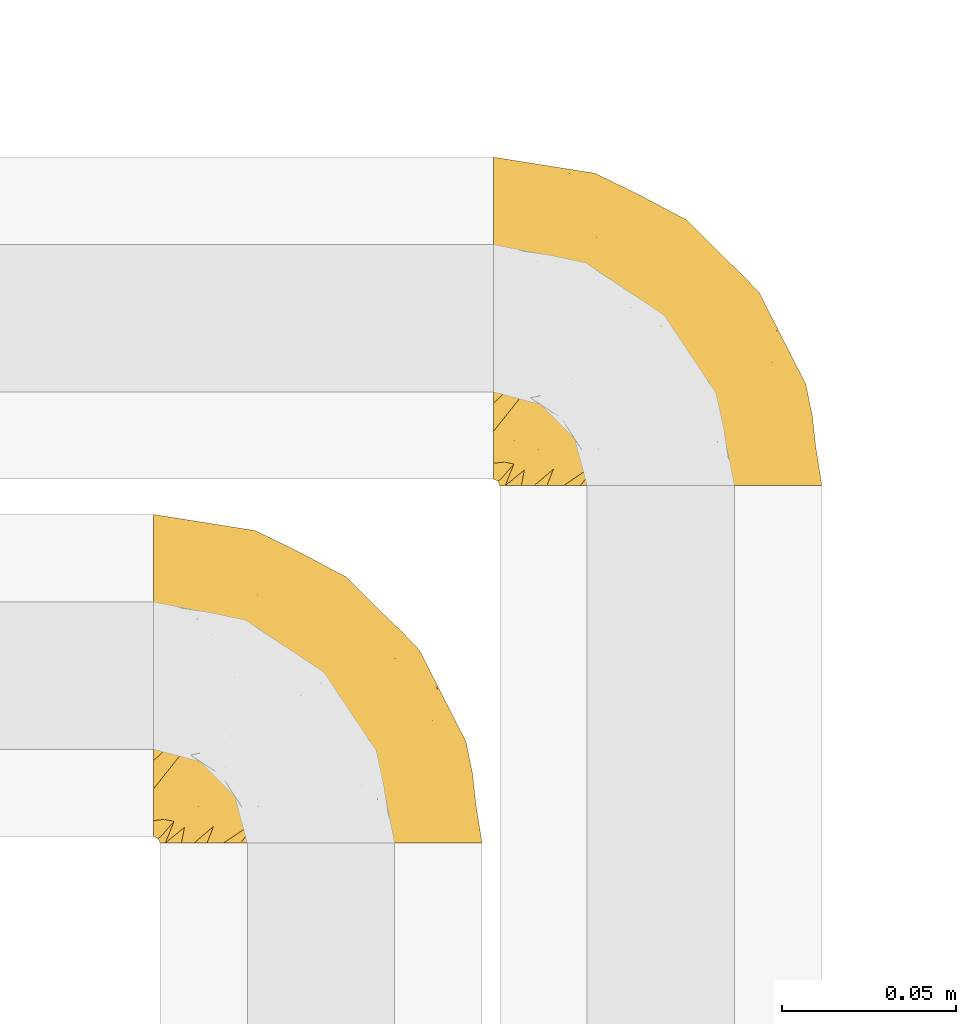
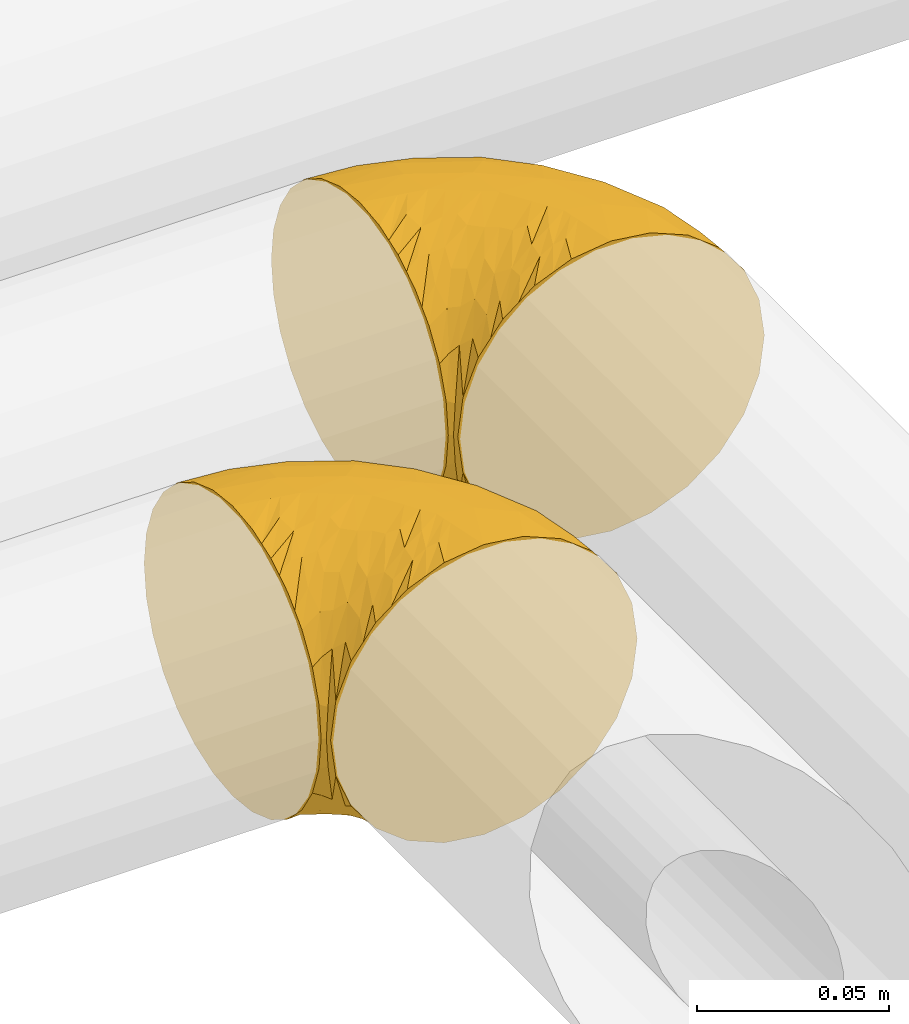
# One storey, part 322 of 827: 2 coverings.
"""IFC2X3 building model written with IfcOpenShell, lengths in millimetres."""

from ifc_helpers import new_model, entity, si_unit, converted_unit, derived_unit, direction, frame, origin, place, context, subcontext, project, spatial, faceted_brep, element, save


model = new_model("IFC2X3")

# Units and contexts
model_context = context("Model", 3, precision=0.01, world=origin(), true_north=direction((6.12303176911189e-17, 1.0)))
body_context = subcontext(model_context, "Body", "Model", "MODEL_VIEW")
ifc_project = project(units=[si_unit("LENGTHUNIT", "METRE", prefix="MILLI"), si_unit("AREAUNIT", "SQUARE_METRE"), si_unit("VOLUMEUNIT", "CUBIC_METRE"), converted_unit("PLANEANGLEUNIT", "DEGREE", entity("IfcRatioMeasure", 0.0174532925199433), si_unit("PLANEANGLEUNIT", "RADIAN"), dimensions=[0, 0, 0, 0, 0, 0, 0]), si_unit("MASSUNIT", "GRAM", prefix="KILO"), derived_unit("MASSDENSITYUNIT", [(si_unit("MASSUNIT", "GRAM", prefix="KILO"), 1), (si_unit("LENGTHUNIT", "METRE"), -3)]), derived_unit("MOMENTOFINERTIAUNIT", [(si_unit("LENGTHUNIT", "METRE"), 4)]), si_unit("TIMEUNIT", "SECOND"), si_unit("FREQUENCYUNIT", "HERTZ"), si_unit("THERMODYNAMICTEMPERATUREUNIT", "DEGREE_CELSIUS"), derived_unit("THERMALTRANSMITTANCEUNIT", [(si_unit("MASSUNIT", "GRAM", prefix="KILO"), 1), (si_unit("THERMODYNAMICTEMPERATUREUNIT", "KELVIN"), -1), (si_unit("TIMEUNIT", "SECOND"), -3)]), derived_unit("VOLUMETRICFLOWRATEUNIT", [(si_unit("LENGTHUNIT", "METRE"), 3), (si_unit("TIMEUNIT", "SECOND"), -1)]), derived_unit("MASSFLOWRATEUNIT", [(si_unit("MASSUNIT", "GRAM", prefix="KILO"), 1), (si_unit("TIMEUNIT", "SECOND"), -1)]), derived_unit("ROTATIONALFREQUENCYUNIT", [(si_unit("TIMEUNIT", "SECOND"), -1)]), si_unit("ELECTRICCURRENTUNIT", "AMPERE"), si_unit("ELECTRICVOLTAGEUNIT", "VOLT"), si_unit("POWERUNIT", "WATT"), si_unit("FORCEUNIT", "NEWTON", prefix="KILO"), si_unit("ILLUMINANCEUNIT", "LUX"), si_unit("LUMINOUSFLUXUNIT", "LUMEN"), si_unit("LUMINOUSINTENSITYUNIT", "CANDELA"), derived_unit("USERDEFINED", [(si_unit("MASSUNIT", "GRAM", prefix="KILO"), -1), (si_unit("LENGTHUNIT", "METRE"), -2), (si_unit("TIMEUNIT", "SECOND"), 3), (si_unit("LUMINOUSFLUXUNIT", "LUMEN"), 1)]), derived_unit("LINEARVELOCITYUNIT", [(si_unit("LENGTHUNIT", "METRE"), 1), (si_unit("TIMEUNIT", "SECOND"), -1)]), si_unit("PRESSUREUNIT", "PASCAL"), derived_unit("USERDEFINED", [(si_unit("LENGTHUNIT", "METRE"), -2), (si_unit("MASSUNIT", "GRAM", prefix="KILO"), 1), (si_unit("TIMEUNIT", "SECOND"), -2)]), derived_unit("LINEARFORCEUNIT", [(si_unit("MASSUNIT", "GRAM", prefix="KILO"), 1), (si_unit("LENGTHUNIT", "METRE"), 1), (si_unit("TIMEUNIT", "SECOND"), -2), (si_unit("LENGTHUNIT", "METRE"), -1)]), derived_unit("PLANARFORCEUNIT", [(si_unit("MASSUNIT", "GRAM", prefix="KILO"), 1), (si_unit("LENGTHUNIT", "METRE"), 1), (si_unit("TIMEUNIT", "SECOND"), -2), (si_unit("LENGTHUNIT", "METRE"), -2)])], contexts=[model_context])

# Site, building, storey
site_placement = place(None, origin())
site = spatial("IfcSite", under=ifc_project, at=site_placement, CompositionType="ELEMENT")
building_placement = place(site_placement, origin())
building = spatial("IfcBuilding", under=site, at=building_placement, CompositionType="ELEMENT")
storey_placement = place(building_placement, frame((0.0, 0.0, 28200.0)))
storey = spatial("IfcBuildingStorey", under=building, at=storey_placement, Name="08", CompositionType="ELEMENT", Elevation=28200.0)

# Coverings
covering_1_placement = place(storey_placement, frame((32320.44, 18547.91, 2951.71)))
element("IfcCovering", 1, at=covering_1_placement, inside=storey, Name=":ADSK_", ObjectType=":ADSK_", PredefinedType="INSULATION", context=body_context, shape_type="Brep", body=[
    faceted_brep([(1.6, 59.88, 92.84), (1.6, 69.65, 89.42), (1.6, 78.41, 83.91), (1.6, 85.72, 76.59), (1.6, 91.22, 67.83), (1.6, 94.64, 58.07), (1.6, 95.8, 47.8), (1.6, 94.64, 37.51), (1.6, 91.22, 27.74), (1.6, 85.71, 18.98), (1.6, 78.39, 11.67), (1.6, 69.63, 6.17), (1.6, 59.87, 2.75), (1.6, 49.6, 1.6), (1.6, 45.45, 2.06), (1.6, 42.38, 2.41), (1.6, 39.31, 2.75), (1.6, 34.43, 4.46), (1.6, 29.54, 6.17), (1.6, 25.16, 8.93), (1.6, 20.78, 11.68), (1.6, 17.13, 15.34), (1.6, 13.47, 19.0), (1.6, 7.97, 27.76), (1.6, 6.26, 32.64), (1.6, 4.55, 37.52), (1.6, 3.4, 47.8), (1.6, 4.55, 58.08), (1.6, 6.26, 62.96), (1.6, 7.97, 67.85), (1.6, 13.48, 76.61), (1.6, 17.14, 80.26), (1.6, 20.8, 83.92), (1.6, 25.18, 86.67), (1.6, 29.56, 89.42), (1.6, 34.44, 91.13), (1.6, 39.32, 92.84), (1.6, 42.39, 93.18), (1.6, 45.45, 93.53), (1.6, 49.6, 94.0), (3.4, 1.6, 47.8), (4.97, 1.6, 35.84), (9.58, 1.6, 24.7), (13.26, 1.6, 19.91), (16.93, 1.6, 15.13), (21.71, 1.6, 11.46), (26.5, 1.6, 7.78), (32.07, 1.6, 5.48), (37.64, 1.6, 3.17), (41.25, 1.6, 2.69), (43.34, 1.6, 2.42), (45.42, 1.6, 2.14), (49.6, 1.6, 1.6), (61.55, 1.6, 3.17), (72.7, 1.6, 7.78), (82.26, 1.6, 15.13), (89.61, 1.6, 24.7), (94.22, 1.6, 35.84), (95.8, 1.6, 47.8), (94.22, 1.6, 59.75), (89.61, 1.6, 70.9), (82.26, 1.6, 80.46), (72.7, 1.6, 87.81), (61.55, 1.6, 92.42), (49.6, 1.6, 94.0), (45.42, 1.6, 93.45), (41.25, 1.6, 92.9), (37.64, 1.6, 92.42), (32.07, 1.6, 90.11), (26.5, 1.6, 87.81), (21.71, 1.6, 84.13), (16.93, 1.6, 80.46), (13.26, 1.6, 75.68), (9.58, 1.6, 70.9), (4.97, 1.6, 59.75), (81.55, 36.81, 71.98), (90.4, 23.28, 63.6), (83.0, 45.8, 59.72), (91.18, 30.7, 47.8), (93.13, 21.2, 55.16), (94.0, 12.96, 47.8), (66.19, 66.19, 63.76), (70.92, 54.51, 72.22), (85.95, 17.98, 74.18), (49.74, 36.69, 92.52), (35.54, 35.54, 94.0), (38.14, 31.64, 94.0), (40.74, 27.75, 94.0), (43.34, 23.86, 94.0), (45.94, 19.96, 94.0), (77.59, 22.8, 82.14), (71.17, 42.67, 80.34), (65.81, 33.21, 87.52), (59.03, 59.45, 79.59), (45.85, 71.5, 78.25), (45.79, 62.66, 85.01), (41.42, 54.5, 90.25), (34.51, 47.57, 93.2), (56.04, 48.81, 87.23), (15.15, 74.98, 85.55), (56.51, 18.7, 93.0), (68.39, 15.75, 89.31), (23.33, 91.17, 61.31), (42.86, 85.28, 56.86), (39.42, 82.58, 68.34), (53.58, 75.78, 65.71), (59.17, 74.98, 56.99), (59.06, 67.27, 72.15), (22.63, 87.38, 70.34), (20.55, 82.04, 78.36), (12.96, 94.0, 47.8), (56.96, 77.8, 47.8), (67.38, 67.38, 47.8), (18.72, 56.2, 93.06), (5.33, 48.85, 94.0), (9.07, 48.11, 94.0), (11.79, 47.57, 94.0), (14.51, 47.03, 94.0), (17.24, 46.48, 94.0), (19.96, 45.94, 94.0), (21.03, 65.78, 89.88), (46.48, 17.24, 94.0), (47.03, 14.51, 94.0), (47.57, 11.79, 94.0), (48.11, 9.07, 94.0), (48.48, 7.2, 94.0), (48.85, 5.33, 94.0), (30.7, 91.18, 47.8), (23.86, 43.34, 94.0), (27.75, 40.74, 94.0), (31.64, 38.14, 94.0), (31.26, 72.73, 83.7), (77.8, 56.96, 47.8), (72.75, 62.23, 55.9), (43.83, 84.49, 47.8), (84.49, 43.83, 47.8), (14.58, 12.05, 81.75), (16.17, 18.95, 86.43), (10.82, 13.02, 79.8), (4.64, 8.34, 69.84), (7.71, 14.63, 79.5), (25.13, 11.09, 88.08), (32.66, 13.66, 91.6), (34.94, 20.08, 92.93), (36.76, 9.61, 92.43), (40.48, 9.48, 93.24), (39.25, 16.1, 93.36), (3.69, 3.42, 57.25), (13.99, 26.63, 89.41), (21.85, 33.72, 92.89), (17.93, 34.77, 92.66), (15.11, 6.75, 79.58), (21.14, 13.31, 86.51), (12.7, 21.11, 86.29), (7.21, 19.94, 83.91), (10.45, 6.04, 73.94), (32.27, 8.67, 90.94), (25.68, 26.11, 91.94), (22.18, 29.3, 91.98), (18.79, 6.32, 82.79), (10.12, 39.92, 93.16), (9.47, 27.05, 88.76), (11.29, 34.4, 91.89), (2.87, 2.87, 47.8), (31.16, 20.92, 92.22), (6.31, 27.43, 88.56), (25.62, 7.54, 87.72), (21.18, 18.45, 88.33), (28.81, 23.88, 92.18), (7.45, 7.77, 71.78), (21.14, 13.3, 9.09), (25.13, 11.09, 7.51), (18.79, 6.33, 12.8), (48.11, 9.07, 1.6), (48.85, 5.33, 1.6), (47.03, 14.51, 1.6), (47.57, 11.79, 1.6), (3.69, 3.42, 38.35), (7.44, 7.76, 23.84), (14.51, 47.03, 1.6), (11.79, 47.57, 1.6), (5.33, 48.85, 1.6), (9.07, 48.11, 1.6), (7.71, 14.62, 16.1), (9.47, 27.03, 6.84), (34.94, 20.08, 2.66), (31.16, 20.92, 3.37), (40.74, 27.75, 1.6), (38.14, 31.64, 1.6), (36.76, 9.61, 3.16), (40.48, 9.48, 2.35), (4.63, 8.33, 25.77), (15.11, 6.74, 16.02), (14.58, 12.04, 13.85), (43.34, 23.86, 1.6), (45.94, 19.96, 1.6), (39.25, 16.1, 2.23), (7.21, 19.93, 11.69), (12.69, 21.1, 9.31), (10.14, 39.92, 2.43), (21.81, 33.68, 2.71), (22.19, 29.28, 3.61), (14.0, 26.62, 6.18), (25.69, 26.08, 3.66), (16.17, 18.93, 9.17), (6.66, 27.87, 6.77), (17.92, 34.75, 2.93), (10.45, 6.04, 21.66), (31.64, 38.14, 1.6), (10.64, 12.79, 16.09), (11.31, 34.41, 3.7), (19.96, 45.94, 1.6), (23.86, 43.34, 1.6), (27.75, 40.74, 1.6), (32.66, 13.66, 3.99), (46.48, 17.24, 1.6), (32.27, 8.67, 4.65), (35.54, 35.54, 1.6), (28.77, 23.83, 3.43), (21.17, 18.43, 7.27), (23.36, 6.03, 9.46), (17.24, 46.48, 1.6), (47.58, 34.52, 2.4), (93.13, 21.2, 40.43), (77.44, 23.82, 13.57), (66.78, 41.32, 11.3), (71.68, 47.62, 18.65), (74.96, 52.66, 27.26), (81.55, 36.81, 23.61), (36.7, 49.75, 3.07), (56.9, 19.07, 2.69), (83.0, 45.8, 35.87), (90.4, 23.28, 31.99), (67.83, 21.35, 6.71), (85.95, 17.98, 21.41), (39.41, 82.57, 27.24), (23.33, 91.17, 34.26), (42.87, 85.27, 38.73), (53.92, 73.89, 26.97), (66.19, 66.19, 31.83), (64.12, 62.43, 23.4), (33.13, 63.53, 6.91), (23.1, 58.45, 3.4), (16.98, 67.16, 5.84), (72.75, 62.22, 39.69), (23.77, 81.54, 17.6), (18.41, 74.8, 10.38), (43.7, 75.83, 20.6), (54.53, 41.45, 5.36), (55.72, 76.72, 35.73), (17.73, 88.2, 24.84), (38.98, 71.6, 13.87), (50.28, 56.23, 9.06), (59.02, 59.44, 15.99)], [[[0, 1, 2, 3, 4, 5, 6, 7, 8, 9, 10, 11, 12, 13, 14, 15, 16, 17, 18, 19, 20, 21, 22, 23, 24, 25, 26, 27, 28, 29, 30, 31, 32, 33, 34, 35, 36, 37, 38, 39]], [[40, 41, 42, 43, 44, 45, 46, 47, 48, 49, 50, 51, 52, 53, 54, 55, 56, 57, 58, 59, 60, 61, 62, 63, 64, 65, 66, 67, 68, 69, 70, 71, 72, 73, 74]], [[75, 76, 77]], [[78, 79, 80]], [[77, 81, 82]], [[76, 75, 83]], [[84, 85, 86, 87, 88, 89]], [[90, 91, 92]], [[76, 60, 59]], [[93, 94, 95]], [[90, 62, 61]], [[83, 61, 60]], [[96, 97, 84]], [[98, 93, 95]], [[2, 1, 99]], [[100, 84, 89]], [[62, 101, 63]], [[4, 102, 5]], [[92, 84, 100]], [[103, 102, 104]], [[103, 105, 106]], [[93, 107, 94]], [[3, 108, 4]], [[92, 101, 90]], [[108, 3, 109]], [[102, 110, 5]], [[93, 82, 107]], [[102, 108, 104]], [[111, 106, 112]], [[109, 2, 99]], [[113, 39, 114, 115, 116, 117, 118, 119]], [[120, 0, 113]], [[100, 89, 121, 122, 123, 124, 125, 126, 64]], [[127, 102, 103]], [[97, 119, 128, 129, 130, 85]], [[99, 120, 131]], [[132, 133, 77]], [[59, 80, 79]], [[3, 2, 109]], [[98, 84, 92]], [[94, 109, 131]], [[120, 1, 0]], [[93, 91, 82]], [[104, 94, 105]], [[97, 113, 119]], [[95, 120, 96]], [[83, 90, 61]], [[91, 93, 98]], [[64, 63, 100]], [[100, 63, 101]], [[77, 76, 79]], [[133, 106, 81]], [[84, 97, 85]], [[113, 96, 120]], [[113, 97, 96]], [[39, 113, 0]], [[110, 102, 127]], [[110, 6, 5]], [[103, 111, 134, 127]], [[90, 75, 91]], [[82, 81, 107]], [[91, 75, 82]], [[77, 82, 75]], [[76, 83, 60]], [[90, 83, 75]], [[105, 107, 81]], [[94, 131, 95]], [[105, 94, 107]], [[109, 94, 104]], [[120, 95, 131]], [[98, 95, 96]], [[84, 98, 96]], [[98, 92, 91]], [[106, 105, 81]], [[103, 104, 105]], [[133, 132, 112]], [[103, 106, 111]], [[77, 78, 135, 132]], [[106, 133, 112]], [[77, 133, 81]], [[120, 99, 1]], [[109, 99, 131]], [[59, 58, 80]], [[59, 79, 76]], [[90, 101, 62]], [[100, 101, 92]], [[4, 108, 102]], [[109, 104, 108]], [[78, 77, 79]], [[136, 137, 138]], [[29, 139, 140]], [[141, 142, 143]], [[144, 145, 121]], [[146, 89, 88]], [[147, 139, 27]], [[148, 149, 150]], [[136, 151, 152]], [[147, 40, 74]], [[26, 147, 27]], [[140, 153, 154]], [[35, 116, 36]], [[73, 151, 155]], [[114, 39, 38, 37, 36, 116, 115]], [[146, 156, 144]], [[157, 85, 130]], [[158, 149, 148]], [[151, 159, 152]], [[117, 35, 160]], [[31, 154, 161]], [[155, 74, 73]], [[162, 128, 119]], [[66, 65, 64, 126, 125, 124, 123, 122, 67]], [[163, 147, 26]], [[29, 140, 30]], [[149, 129, 150]], [[139, 29, 28, 27]], [[68, 144, 69]], [[129, 128, 150]], [[164, 87, 86]], [[130, 129, 149]], [[122, 145, 67]], [[154, 153, 148]], [[162, 119, 160]], [[165, 32, 161]], [[150, 161, 148]], [[128, 162, 150]], [[32, 165, 33]], [[145, 144, 68]], [[89, 146, 144]], [[87, 164, 143]], [[166, 156, 142]], [[88, 87, 143]], [[162, 161, 150]], [[161, 32, 31]], [[154, 31, 30]], [[140, 154, 30]], [[161, 154, 148]], [[140, 137, 153]], [[158, 148, 153]], [[157, 130, 158]], [[153, 137, 158]], [[158, 137, 157]], [[167, 137, 136]], [[168, 85, 157]], [[152, 168, 167]], [[167, 168, 157]], [[164, 152, 141]], [[151, 73, 72]], [[159, 72, 71]], [[88, 142, 146]], [[144, 156, 69]], [[146, 142, 156]], [[70, 166, 71]], [[142, 141, 166]], [[70, 69, 156]], [[141, 159, 71]], [[167, 136, 152]], [[138, 137, 140]], [[155, 136, 169]], [[136, 155, 151]], [[74, 155, 169]], [[152, 159, 141]], [[151, 72, 159]], [[168, 152, 164]], [[137, 167, 157]], [[164, 86, 168]], [[85, 168, 86]], [[116, 35, 117]], [[130, 149, 158]], [[67, 145, 68]], [[121, 89, 144]], [[145, 122, 121]], [[40, 147, 163]], [[169, 147, 74]], [[160, 35, 34]], [[162, 160, 34]], [[160, 119, 118, 117]], [[139, 147, 169]], [[139, 169, 138]], [[162, 34, 33]], [[141, 143, 164]], [[88, 143, 142]], [[71, 166, 141]], [[156, 166, 70]], [[139, 138, 140]], [[169, 136, 138]], [[161, 162, 165]], [[162, 33, 165]], [[170, 171, 172]], [[173, 174, 52, 51, 50, 49, 48, 175, 176]], [[177, 178, 41]], [[179, 17, 180]], [[14, 13, 181, 182, 180, 16, 15]], [[183, 23, 22]], [[21, 20, 184]], [[185, 186, 187]], [[186, 188, 187]], [[43, 172, 44]], [[189, 190, 47]], [[25, 24, 23, 191]], [[170, 192, 193]], [[40, 163, 177]], [[194, 195, 196]], [[26, 25, 177]], [[197, 198, 183]], [[199, 17, 179]], [[47, 46, 189]], [[200, 201, 202]], [[201, 203, 204]], [[205, 206, 184]], [[207, 41, 178]], [[18, 17, 199]], [[16, 180, 17]], [[202, 201, 198]], [[208, 201, 200]], [[163, 26, 177]], [[48, 47, 190]], [[196, 195, 189]], [[197, 184, 202]], [[204, 193, 209]], [[210, 211, 212]], [[206, 212, 213]], [[205, 19, 210]], [[184, 206, 202]], [[210, 212, 206]], [[185, 194, 214]], [[189, 215, 190]], [[216, 45, 214]], [[186, 171, 170]], [[189, 216, 196]], [[21, 184, 197]], [[194, 185, 187]], [[21, 197, 22]], [[198, 197, 202]], [[183, 22, 197]], [[206, 200, 202]], [[204, 183, 198]], [[201, 208, 203]], [[203, 208, 217]], [[204, 198, 201]], [[217, 188, 218]], [[193, 219, 170]], [[171, 186, 185]], [[170, 218, 186]], [[170, 219, 218]], [[42, 207, 192]], [[171, 220, 172]], [[216, 189, 46]], [[214, 194, 196]], [[44, 220, 45]], [[214, 196, 216]], [[216, 46, 45]], [[214, 45, 220]], [[192, 43, 42]], [[204, 203, 219]], [[207, 193, 192]], [[209, 193, 178]], [[41, 207, 42]], [[193, 207, 178]], [[43, 192, 172]], [[170, 172, 192]], [[204, 219, 193]], [[219, 203, 218]], [[217, 218, 203]], [[188, 186, 218]], [[206, 213, 200]], [[208, 200, 213]], [[199, 210, 18]], [[215, 189, 195]], [[215, 175, 190]], [[175, 48, 190]], [[199, 179, 221, 211]], [[210, 199, 211]], [[25, 191, 177]], [[40, 177, 41]], [[178, 177, 191]], [[23, 183, 191]], [[209, 191, 183]], [[205, 20, 19]], [[19, 18, 210]], [[171, 185, 214]], [[172, 220, 44]], [[214, 220, 171]], [[191, 209, 178]], [[204, 209, 183]], [[206, 205, 210]], [[20, 205, 184]], [[222, 195, 194, 187, 188, 217]], [[57, 223, 80]], [[224, 225, 226]], [[226, 227, 228]], [[229, 217, 208, 213, 212, 211]], [[230, 52, 174, 173, 176, 175, 215, 195]], [[231, 232, 228]], [[231, 78, 223]], [[223, 57, 232]], [[224, 233, 225]], [[233, 54, 53]], [[234, 232, 56]], [[56, 55, 234]], [[234, 224, 228]], [[235, 236, 237]], [[224, 55, 54]], [[238, 239, 240]], [[52, 230, 53]], [[241, 242, 243]], [[231, 227, 244]], [[13, 12, 242]], [[236, 8, 7]], [[9, 245, 10]], [[10, 246, 11]], [[238, 247, 235]], [[222, 229, 248]], [[242, 211, 221, 179, 180, 182, 181, 13]], [[233, 53, 230]], [[111, 112, 249]], [[250, 8, 236]], [[246, 251, 241]], [[8, 250, 9]], [[127, 236, 110]], [[248, 229, 252]], [[246, 10, 245]], [[235, 245, 250]], [[236, 7, 110]], [[235, 249, 238]], [[237, 236, 127]], [[243, 11, 246]], [[252, 229, 241]], [[56, 232, 57]], [[222, 230, 195]], [[225, 248, 252]], [[248, 233, 230]], [[54, 233, 224]], [[231, 228, 227]], [[244, 132, 231]], [[248, 225, 233]], [[226, 225, 253]], [[235, 250, 236]], [[245, 9, 250]], [[251, 246, 245]], [[243, 246, 241]], [[247, 245, 235]], [[252, 251, 253]], [[229, 222, 217]], [[230, 222, 248]], [[7, 6, 110]], [[237, 127, 134, 111]], [[238, 249, 239]], [[224, 234, 55]], [[232, 234, 228]], [[242, 241, 229]], [[12, 11, 243]], [[211, 242, 229]], [[12, 243, 242]], [[80, 223, 78]], [[80, 58, 57]], [[231, 223, 232]], [[227, 240, 239]], [[224, 226, 228]], [[240, 226, 253]], [[227, 239, 244]], [[226, 240, 227]], [[251, 247, 253]], [[240, 253, 247]], [[249, 235, 237]], [[237, 111, 249]], [[244, 239, 249]], [[112, 244, 249]], [[135, 78, 231, 132]], [[112, 132, 244]], [[247, 238, 240]], [[245, 247, 251]], [[251, 252, 241]], [[225, 252, 253]]]),
])
covering_2_placement = place(storey_placement, frame((32417.93, 18650.41, 2952.11)))
element("IfcCovering", 2, at=covering_2_placement, inside=storey, Name=":ADSK_", ObjectType=":ADSK_", PredefinedType="INSULATION", context=body_context, shape_type="Brep", body=[
    faceted_brep([(1.6, 59.88, 92.84), (1.6, 69.65, 89.42), (1.6, 78.41, 83.91), (1.6, 85.72, 76.59), (1.6, 91.22, 67.83), (1.6, 94.64, 58.07), (1.6, 95.8, 47.8), (1.6, 94.64, 37.51), (1.6, 91.22, 27.74), (1.6, 85.71, 18.98), (1.6, 78.39, 11.67), (1.6, 69.63, 6.17), (1.6, 59.87, 2.75), (1.6, 49.6, 1.6), (1.6, 45.45, 2.06), (1.6, 42.38, 2.41), (1.6, 39.31, 2.75), (1.6, 34.43, 4.46), (1.6, 29.54, 6.17), (1.6, 25.16, 8.93), (1.6, 20.78, 11.68), (1.6, 17.13, 15.34), (1.6, 13.47, 19.0), (1.6, 7.97, 27.76), (1.6, 6.26, 32.64), (1.6, 4.55, 37.52), (1.6, 3.4, 47.8), (1.6, 4.55, 58.08), (1.6, 6.26, 62.96), (1.6, 7.97, 67.85), (1.6, 13.48, 76.61), (1.6, 17.14, 80.26), (1.6, 20.8, 83.92), (1.6, 25.18, 86.67), (1.6, 29.56, 89.42), (1.6, 34.44, 91.13), (1.6, 39.32, 92.84), (1.6, 42.39, 93.18), (1.6, 45.45, 93.53), (1.6, 49.6, 94.0), (3.4, 1.6, 47.8), (4.97, 1.6, 35.84), (9.58, 1.6, 24.7), (13.26, 1.6, 19.91), (16.93, 1.6, 15.13), (21.71, 1.6, 11.46), (26.5, 1.6, 7.78), (32.07, 1.6, 5.48), (37.64, 1.6, 3.17), (41.25, 1.6, 2.69), (43.34, 1.6, 2.42), (45.42, 1.6, 2.14), (49.6, 1.6, 1.6), (61.55, 1.6, 3.17), (72.7, 1.6, 7.78), (82.26, 1.6, 15.13), (89.61, 1.6, 24.7), (94.22, 1.6, 35.84), (95.8, 1.6, 47.8), (94.22, 1.6, 59.75), (89.61, 1.6, 70.9), (82.26, 1.6, 80.46), (72.7, 1.6, 87.81), (61.55, 1.6, 92.42), (49.6, 1.6, 94.0), (45.42, 1.6, 93.45), (41.25, 1.6, 92.9), (37.64, 1.6, 92.42), (32.07, 1.6, 90.11), (26.5, 1.6, 87.81), (21.71, 1.6, 84.13), (16.93, 1.6, 80.46), (13.26, 1.6, 75.68), (9.58, 1.6, 70.9), (4.97, 1.6, 59.75), (81.55, 36.81, 71.98), (90.4, 23.28, 63.6), (83.0, 45.8, 59.72), (91.18, 30.7, 47.8), (93.13, 21.2, 55.16), (94.0, 12.96, 47.8), (66.19, 66.19, 63.76), (70.92, 54.51, 72.22), (85.95, 17.98, 74.18), (49.74, 36.69, 92.52), (35.54, 35.54, 94.0), (38.14, 31.64, 94.0), (40.74, 27.75, 94.0), (43.34, 23.86, 94.0), (45.94, 19.96, 94.0), (77.59, 22.8, 82.14), (71.17, 42.67, 80.34), (65.81, 33.21, 87.52), (59.03, 59.45, 79.59), (45.85, 71.5, 78.25), (45.79, 62.66, 85.01), (41.42, 54.5, 90.25), (34.51, 47.57, 93.2), (56.04, 48.81, 87.23), (15.15, 74.98, 85.55), (56.51, 18.7, 93.0), (68.39, 15.75, 89.31), (23.33, 91.17, 61.31), (42.86, 85.28, 56.86), (39.42, 82.58, 68.34), (53.58, 75.78, 65.71), (59.17, 74.98, 56.99), (59.06, 67.27, 72.15), (22.63, 87.38, 70.34), (20.55, 82.04, 78.36), (12.96, 94.0, 47.8), (56.96, 77.8, 47.8), (67.38, 67.38, 47.8), (18.72, 56.2, 93.06), (5.33, 48.85, 94.0), (9.07, 48.11, 94.0), (11.79, 47.57, 94.0), (14.51, 47.03, 94.0), (17.24, 46.48, 94.0), (19.96, 45.94, 94.0), (21.03, 65.78, 89.88), (46.48, 17.24, 94.0), (47.03, 14.51, 94.0), (47.57, 11.79, 94.0), (48.11, 9.07, 94.0), (48.48, 7.2, 94.0), (48.85, 5.33, 94.0), (30.7, 91.18, 47.8), (23.86, 43.34, 94.0), (27.75, 40.74, 94.0), (31.64, 38.14, 94.0), (31.26, 72.73, 83.7), (77.8, 56.96, 47.8), (72.75, 62.23, 55.9), (43.83, 84.49, 47.8), (84.49, 43.83, 47.8), (14.58, 12.05, 81.75), (16.17, 18.95, 86.43), (10.82, 13.02, 79.8), (4.64, 8.34, 69.84), (7.71, 14.63, 79.5), (25.13, 11.09, 88.08), (32.66, 13.66, 91.6), (34.94, 20.08, 92.93), (36.76, 9.61, 92.43), (40.48, 9.48, 93.24), (39.25, 16.1, 93.36), (3.69, 3.42, 57.25), (13.99, 26.63, 89.41), (21.85, 33.72, 92.89), (17.93, 34.77, 92.66), (15.11, 6.75, 79.58), (21.14, 13.31, 86.51), (12.7, 21.11, 86.29), (7.21, 19.94, 83.91), (10.45, 6.04, 73.94), (32.27, 8.67, 90.94), (25.68, 26.11, 91.94), (22.18, 29.3, 91.98), (18.79, 6.32, 82.79), (10.12, 39.92, 93.16), (9.47, 27.05, 88.76), (11.29, 34.4, 91.89), (2.87, 2.87, 47.8), (31.16, 20.92, 92.22), (6.31, 27.43, 88.56), (25.62, 7.54, 87.72), (21.18, 18.45, 88.33), (28.81, 23.88, 92.18), (7.45, 7.77, 71.78), (21.17, 18.43, 7.27), (16.17, 18.93, 9.17), (25.69, 26.08, 3.66), (48.11, 9.07, 1.6), (48.85, 5.33, 1.6), (47.03, 14.51, 1.6), (47.57, 11.79, 1.6), (3.69, 3.42, 38.35), (7.44, 7.76, 23.84), (14.51, 47.03, 1.6), (11.79, 47.57, 1.6), (5.33, 48.85, 1.6), (9.07, 48.11, 1.6), (7.71, 14.62, 16.1), (9.47, 27.03, 6.84), (34.94, 20.08, 2.66), (31.16, 20.92, 3.37), (40.74, 27.75, 1.6), (38.14, 31.64, 1.6), (18.79, 6.33, 12.8), (36.76, 9.61, 3.16), (40.48, 9.48, 2.35), (4.63, 8.33, 25.77), (21.14, 13.3, 9.09), (15.11, 6.74, 16.02), (14.58, 12.04, 13.85), (43.34, 23.86, 1.6), (45.94, 19.96, 1.6), (39.25, 16.1, 2.23), (7.21, 19.93, 11.69), (12.69, 21.1, 9.31), (10.14, 39.92, 2.43), (21.81, 33.68, 2.71), (22.19, 29.28, 3.61), (14.0, 26.62, 6.18), (6.66, 27.87, 6.77), (17.92, 34.75, 2.93), (10.45, 6.04, 21.66), (31.64, 38.14, 1.6), (10.64, 12.79, 16.09), (11.31, 34.41, 3.7), (19.96, 45.94, 1.6), (23.86, 43.34, 1.6), (27.75, 40.74, 1.6), (32.66, 13.66, 3.99), (46.48, 17.24, 1.6), (32.27, 8.67, 4.65), (25.13, 11.09, 7.51), (35.54, 35.54, 1.6), (28.77, 23.83, 3.43), (23.36, 6.03, 9.46), (17.24, 46.48, 1.6), (47.58, 34.52, 2.4), (93.13, 21.2, 40.43), (77.44, 23.82, 13.57), (66.78, 41.32, 11.3), (71.68, 47.62, 18.65), (74.96, 52.66, 27.26), (81.55, 36.81, 23.61), (36.7, 49.75, 3.07), (56.9, 19.07, 2.69), (83.0, 45.8, 35.87), (90.4, 23.28, 31.99), (67.83, 21.35, 6.71), (85.95, 17.98, 21.41), (39.41, 82.57, 27.24), (23.33, 91.17, 34.26), (42.87, 85.27, 38.73), (53.92, 73.89, 26.97), (66.19, 66.19, 31.83), (64.12, 62.43, 23.4), (33.13, 63.53, 6.91), (23.1, 58.45, 3.4), (16.98, 67.16, 5.84), (72.75, 62.22, 39.69), (23.77, 81.54, 17.6), (18.41, 74.8, 10.38), (43.7, 75.83, 20.6), (54.53, 41.45, 5.36), (55.72, 76.72, 35.73), (17.73, 88.2, 24.84), (38.98, 71.6, 13.87), (50.28, 56.23, 9.06), (59.02, 59.44, 15.99)], [[[0, 1, 2, 3, 4, 5, 6, 7, 8, 9, 10, 11, 12, 13, 14, 15, 16, 17, 18, 19, 20, 21, 22, 23, 24, 25, 26, 27, 28, 29, 30, 31, 32, 33, 34, 35, 36, 37, 38, 39]], [[40, 41, 42, 43, 44, 45, 46, 47, 48, 49, 50, 51, 52, 53, 54, 55, 56, 57, 58, 59, 60, 61, 62, 63, 64, 65, 66, 67, 68, 69, 70, 71, 72, 73, 74]], [[75, 76, 77]], [[78, 79, 80]], [[77, 81, 82]], [[76, 75, 83]], [[84, 85, 86, 87, 88, 89]], [[90, 91, 92]], [[76, 60, 59]], [[93, 94, 95]], [[90, 62, 61]], [[83, 61, 60]], [[96, 97, 84]], [[98, 93, 95]], [[2, 1, 99]], [[100, 84, 89]], [[62, 101, 63]], [[4, 102, 5]], [[92, 84, 100]], [[103, 102, 104]], [[103, 105, 106]], [[93, 107, 94]], [[3, 108, 4]], [[92, 101, 90]], [[108, 3, 109]], [[102, 110, 5]], [[93, 82, 107]], [[102, 108, 104]], [[111, 106, 112]], [[109, 2, 99]], [[113, 39, 114, 115, 116, 117, 118, 119]], [[120, 0, 113]], [[100, 89, 121, 122, 123, 124, 125, 126, 64]], [[127, 102, 103]], [[97, 119, 128, 129, 130, 85]], [[99, 120, 131]], [[132, 133, 77]], [[59, 80, 79]], [[3, 2, 109]], [[98, 84, 92]], [[94, 109, 131]], [[120, 1, 0]], [[93, 91, 82]], [[104, 94, 105]], [[97, 113, 119]], [[95, 120, 96]], [[83, 90, 61]], [[91, 93, 98]], [[64, 63, 100]], [[100, 63, 101]], [[77, 76, 79]], [[133, 106, 81]], [[84, 97, 85]], [[113, 96, 120]], [[113, 97, 96]], [[39, 113, 0]], [[110, 102, 127]], [[110, 6, 5]], [[103, 111, 134, 127]], [[90, 75, 91]], [[82, 81, 107]], [[91, 75, 82]], [[77, 82, 75]], [[76, 83, 60]], [[90, 83, 75]], [[105, 107, 81]], [[94, 131, 95]], [[105, 94, 107]], [[109, 94, 104]], [[120, 95, 131]], [[98, 95, 96]], [[84, 98, 96]], [[98, 92, 91]], [[106, 105, 81]], [[103, 104, 105]], [[112, 106, 133]], [[103, 106, 111]], [[112, 133, 132]], [[81, 77, 133]], [[77, 78, 135, 132]], [[120, 99, 1]], [[109, 99, 131]], [[59, 58, 80]], [[59, 79, 76]], [[90, 101, 62]], [[100, 101, 92]], [[4, 108, 102]], [[109, 104, 108]], [[78, 77, 79]], [[136, 137, 138]], [[29, 139, 140]], [[141, 142, 143]], [[144, 145, 121]], [[146, 89, 88]], [[147, 139, 27]], [[148, 149, 150]], [[136, 151, 152]], [[147, 40, 74]], [[26, 147, 27]], [[140, 153, 154]], [[35, 116, 36]], [[73, 151, 155]], [[114, 39, 38, 37, 36, 116, 115]], [[146, 156, 144]], [[157, 85, 130]], [[158, 149, 148]], [[151, 159, 152]], [[117, 35, 160]], [[31, 154, 161]], [[155, 74, 73]], [[162, 128, 119]], [[66, 65, 64, 126, 125, 124, 123, 122, 67]], [[163, 147, 26]], [[29, 140, 30]], [[149, 129, 150]], [[139, 29, 28, 27]], [[68, 144, 69]], [[129, 128, 150]], [[164, 87, 86]], [[130, 129, 149]], [[122, 145, 67]], [[154, 153, 148]], [[162, 119, 160]], [[165, 32, 161]], [[150, 161, 148]], [[128, 162, 150]], [[32, 165, 33]], [[145, 144, 68]], [[89, 146, 144]], [[87, 164, 143]], [[166, 156, 142]], [[88, 87, 143]], [[162, 161, 150]], [[161, 32, 31]], [[154, 31, 30]], [[140, 154, 30]], [[161, 154, 148]], [[140, 137, 153]], [[158, 148, 153]], [[157, 130, 158]], [[153, 137, 158]], [[158, 137, 157]], [[167, 137, 136]], [[168, 85, 157]], [[152, 168, 167]], [[167, 168, 157]], [[164, 152, 141]], [[151, 73, 72]], [[159, 72, 71]], [[88, 142, 146]], [[144, 156, 69]], [[146, 142, 156]], [[70, 166, 71]], [[142, 141, 166]], [[70, 69, 156]], [[141, 159, 71]], [[167, 136, 152]], [[138, 137, 140]], [[155, 136, 169]], [[136, 155, 151]], [[74, 155, 169]], [[152, 159, 141]], [[151, 72, 159]], [[168, 152, 164]], [[137, 167, 157]], [[164, 86, 168]], [[85, 168, 86]], [[116, 35, 117]], [[130, 149, 158]], [[67, 145, 68]], [[121, 89, 144]], [[145, 122, 121]], [[40, 147, 163]], [[169, 147, 74]], [[160, 35, 34]], [[162, 160, 34]], [[160, 119, 118, 117]], [[139, 147, 169]], [[139, 169, 138]], [[162, 34, 33]], [[141, 143, 164]], [[88, 143, 142]], [[71, 166, 141]], [[156, 166, 70]], [[139, 138, 140]], [[169, 136, 138]], [[161, 162, 165]], [[162, 33, 165]], [[170, 171, 172]], [[173, 174, 52, 51, 50, 49, 48, 175, 176]], [[177, 178, 41]], [[179, 17, 180]], [[14, 13, 181, 182, 180, 16, 15]], [[183, 23, 22]], [[21, 20, 184]], [[185, 186, 187]], [[186, 188, 187]], [[43, 189, 44]], [[190, 191, 47]], [[25, 24, 23, 192]], [[193, 194, 195]], [[40, 163, 177]], [[196, 197, 198]], [[26, 25, 177]], [[199, 200, 183]], [[201, 17, 179]], [[47, 46, 190]], [[202, 203, 204]], [[203, 172, 171]], [[205, 206, 184]], [[207, 41, 178]], [[18, 17, 201]], [[16, 180, 17]], [[204, 203, 200]], [[208, 203, 202]], [[163, 26, 177]], [[48, 47, 191]], [[198, 197, 190]], [[199, 184, 204]], [[171, 195, 209]], [[210, 211, 212]], [[206, 212, 213]], [[205, 19, 210]], [[184, 206, 204]], [[210, 212, 206]], [[185, 196, 214]], [[190, 215, 191]], [[216, 45, 214]], [[186, 217, 193]], [[190, 216, 198]], [[199, 22, 21]], [[196, 185, 187]], [[199, 183, 22]], [[184, 199, 21]], [[199, 204, 200]], [[206, 202, 204]], [[171, 183, 200]], [[203, 208, 172]], [[172, 208, 218]], [[171, 200, 203]], [[218, 188, 219]], [[195, 170, 193]], [[217, 186, 185]], [[193, 219, 186]], [[193, 170, 219]], [[207, 194, 42]], [[217, 220, 189]], [[216, 190, 46]], [[214, 196, 198]], [[44, 220, 45]], [[214, 198, 216]], [[216, 46, 45]], [[214, 45, 220]], [[42, 194, 43]], [[189, 193, 217]], [[207, 195, 194]], [[209, 195, 178]], [[41, 207, 42]], [[195, 207, 178]], [[43, 194, 189]], [[193, 189, 194]], [[171, 170, 195]], [[170, 172, 219]], [[218, 219, 172]], [[188, 186, 219]], [[206, 213, 202]], [[208, 202, 213]], [[201, 210, 18]], [[215, 190, 197]], [[215, 175, 191]], [[175, 48, 191]], [[201, 179, 221, 211]], [[210, 201, 211]], [[25, 192, 177]], [[40, 177, 41]], [[178, 177, 192]], [[23, 183, 192]], [[209, 192, 183]], [[205, 20, 19]], [[19, 18, 210]], [[217, 185, 214]], [[189, 220, 44]], [[214, 220, 217]], [[192, 209, 178]], [[171, 209, 183]], [[206, 205, 210]], [[20, 205, 184]], [[222, 197, 196, 187, 188, 218]], [[57, 223, 80]], [[224, 225, 226]], [[226, 227, 228]], [[229, 218, 208, 213, 212, 211]], [[230, 52, 174, 173, 176, 175, 215, 197]], [[231, 232, 228]], [[231, 78, 223]], [[223, 57, 232]], [[224, 233, 225]], [[233, 54, 53]], [[234, 232, 56]], [[56, 55, 234]], [[234, 224, 228]], [[235, 236, 237]], [[224, 55, 54]], [[238, 239, 240]], [[52, 230, 53]], [[241, 242, 243]], [[227, 244, 231]], [[13, 12, 242]], [[236, 8, 7]], [[9, 245, 10]], [[10, 246, 11]], [[238, 247, 235]], [[222, 229, 248]], [[242, 211, 221, 179, 180, 182, 181, 13]], [[233, 53, 230]], [[111, 112, 249]], [[250, 8, 236]], [[246, 251, 241]], [[8, 250, 9]], [[127, 236, 110]], [[248, 229, 252]], [[246, 10, 245]], [[235, 245, 250]], [[236, 7, 110]], [[235, 249, 238]], [[237, 236, 127]], [[243, 11, 246]], [[252, 229, 241]], [[56, 232, 57]], [[222, 230, 197]], [[225, 248, 252]], [[248, 233, 230]], [[54, 233, 224]], [[231, 228, 227]], [[244, 132, 231]], [[248, 225, 233]], [[226, 225, 253]], [[235, 250, 236]], [[245, 9, 250]], [[251, 246, 245]], [[243, 246, 241]], [[247, 245, 235]], [[252, 251, 253]], [[229, 222, 218]], [[230, 222, 248]], [[7, 6, 110]], [[237, 127, 134, 111]], [[238, 249, 239]], [[224, 234, 55]], [[232, 234, 228]], [[242, 241, 229]], [[12, 11, 243]], [[211, 242, 229]], [[12, 243, 242]], [[80, 223, 78]], [[80, 58, 57]], [[231, 223, 232]], [[227, 240, 239]], [[224, 226, 228]], [[240, 226, 253]], [[227, 239, 244]], [[226, 240, 227]], [[251, 247, 253]], [[240, 253, 247]], [[249, 235, 237]], [[237, 111, 249]], [[112, 132, 244]], [[112, 244, 249]], [[78, 231, 132, 135]], [[249, 244, 239]], [[247, 238, 240]], [[245, 247, 251]], [[251, 252, 241]], [[225, 252, 253]]]),
])

save(model, "model.ifc")
